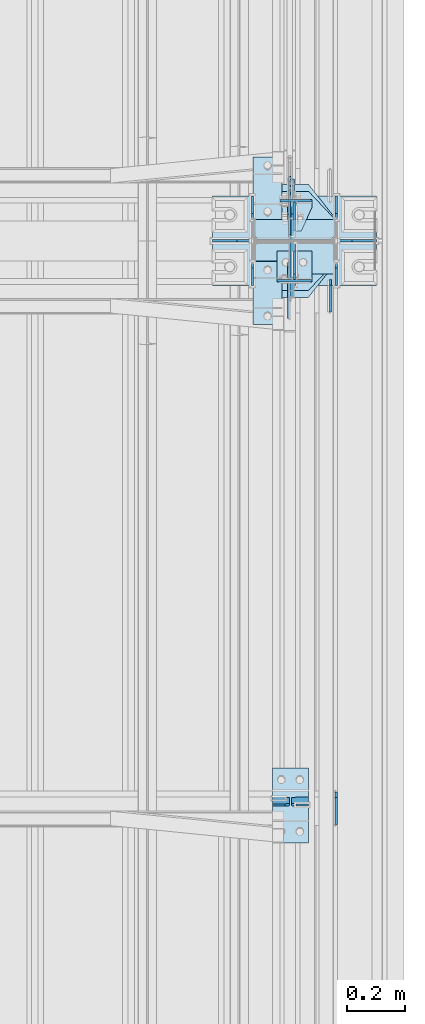
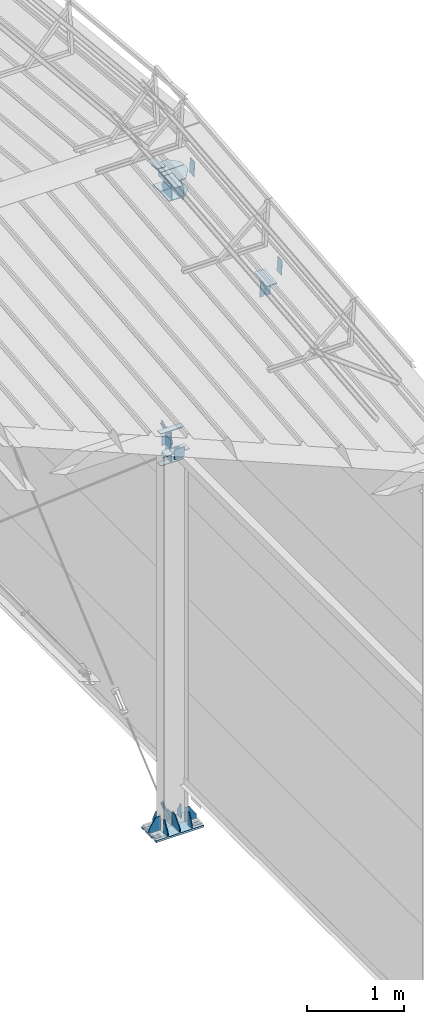
# One storey, part 157 of 709: 38 plates, 4 openings, 11 elements without a shape of their own.
"""IFC4 building model written with IfcOpenShell, lengths in millimetres."""

from ifc_helpers import new_model, si_unit, direction, frame, origin_with_axes, place, context, subcontext, project, spatial, line, arc, indexed_curve, outline, extrude, material, element, aggregate, save


model = new_model("IFC4")

# Units and contexts
model_context = context("Model", 3, precision=0.2, world=origin_with_axes(), true_north=direction((0.0, 1.0)))
body_context = subcontext(model_context, "Body", "Model", "MODEL_VIEW")
ifc_project = project(units=[si_unit("LENGTHUNIT", "METRE", prefix="MILLI"), si_unit("AREAUNIT", "SQUARE_METRE"), si_unit("VOLUMEUNIT", "CUBIC_METRE"), si_unit("MASSUNIT", "GRAM", prefix="KILO"), si_unit("TIMEUNIT", "SECOND"), si_unit("PLANEANGLEUNIT", "RADIAN"), si_unit("SOLIDANGLEUNIT", "STERADIAN"), si_unit("THERMODYNAMICTEMPERATUREUNIT", "DEGREE_CELSIUS"), si_unit("LUMINOUSINTENSITYUNIT", "LUMEN")], contexts=[model_context])

# Site, building, storey
site_placement = place(None, origin_with_axes())
site = spatial("IfcSite", under=ifc_project, at=site_placement, CompositionType="ELEMENT")
building_placement = place(site_placement, origin_with_axes())
building = spatial("IfcBuilding", under=site, at=building_placement, Name="Undefined", CompositionType="ELEMENT")
storey_placement = place(building_placement, origin_with_axes())
storey = spatial("IfcBuildingStorey", under=building, at=storey_placement, Name="Undefined", CompositionType="ELEMENT", Elevation=0.0)

# Assembly, plates
assembly_1_placement = place(storey_placement, frame((49837.5, 5500.0, 7445.307), z_axis=(1.0, 0.0, 0.0), x_axis=(0.0, 0.9950371902, 0.099503719)))
assembly_1 = element("IfcElementAssembly", 1, at=assembly_1_placement, inside=storey)
ifc_material = material(Name="C355-6", Category="STEEL")
plate_1_placement = place(assembly_1_placement, frame((3577.48939, 115.0, 62.0), z_axis=(-1.0, 0.0, 0.0), x_axis=(0.0, 0.0, -1.0)))
plate_1 = element("IfcPlate", 2, at=plate_1_placement, material=ifc_material, ObjectType="594", context=body_context, shape_type="SolidModel", body=[
    extrude(outline(indexed_curve([(0.0, 0.0), (43.5, 0.0), (58.5, 15.0), (58.5, 215.0), (43.5, 230.0), (0.0, 230.0)], segments=[line(1, 2, 3, 4, 5, 6, 1)])), frame((0.0, 0.0, 4.0), z_axis=(0.0, 0.0, 1.0), x_axis=(1.0, 0.0, 0.0)), (0.0, 0.0, -1.0), 8.0),
])
plate_2_placement = place(assembly_1_placement, frame((3577.48939, -115.0, -62.0), z_axis=(-1.0, 0.0, 0.0), x_axis=(0.0, 0.0, 1.0)))
plate_2 = element("IfcPlate", 3, at=plate_2_placement, material=ifc_material, ObjectType="594", context=body_context, shape_type="SolidModel", body=[
    extrude(outline(indexed_curve([(0.0, 0.0), (43.5, 0.0), (58.5, 15.0), (58.5, 215.0), (43.5, 230.0), (0.0, 230.0)], segments=[line(1, 2, 3, 4, 5, 6, 1)])), frame((0.0, 0.0, 4.0), z_axis=(0.0, 0.0, 1.0), x_axis=(1.0, 0.0, 0.0)), (0.0, 0.0, -1.0), 8.0),
])
plate_3_placement = place(assembly_1_placement, frame((5263.56002, 70.0, -6.5), z_axis=(0.0, 0.0, -1.0), x_axis=(1.0, 0.0, 0.0)))
plate_3 = element("IfcPlate", 4, at=plate_3_placement, material=ifc_material, ObjectType="472", context=body_context, shape_type="SolidModel", body=[
    extrude(outline(indexed_curve([(0.0, 0.0), (180.0, 0.0), (180.0, 160.0), (0.0, 160.0)], segments=[line(1, 2, 3, 4, 1)])), frame((0.0, 0.0, 4.0), z_axis=(0.0, 0.0, 1.0), x_axis=(1.0, 0.0, 0.0)), (0.0, 0.0, -1.0), 8.0),
])
aggregate(assembly_1, [plate_1, plate_2, plate_3])

# Assembly, plate
assembly_2_placement = place(storey_placement, frame((49837.5, 16500.0, 7445.307), z_axis=(-1.0, 0.0, 0.0), x_axis=(0.0, -0.9950371902, 0.099503719)))
assembly_2 = element("IfcElementAssembly", 5, at=assembly_2_placement, inside=storey)
plate_4_placement = place(assembly_2_placement, frame((5263.56002, 70.0, 6.5), z_axis=(0.0, 0.0, -1.0), x_axis=(1.0, 0.0, 0.0)))
plate_4 = element("IfcPlate", 6, at=plate_4_placement, material=ifc_material, ObjectType="472", context=body_context, shape_type="SolidModel", body=[
    extrude(outline(indexed_curve([(0.0, 0.0), (180.0, 0.0), (180.0, 160.0), (0.0, 160.0)], segments=[line(1, 2, 3, 4, 1)])), frame((0.0, 0.0, 4.0), z_axis=(0.0, 0.0, 1.0), x_axis=(1.0, 0.0, 0.0)), (0.0, 0.0, -1.0), 8.0),
])
aggregate(assembly_2, [plate_4])

# Assembly, plates
assembly_3_placement = place(storey_placement, frame((49851.0, 5500.0, 4610.0), z_axis=(0.0, 0.0, -1.0), x_axis=(0.0, 1.0, 0.0)))
assembly_3 = element("IfcElementAssembly", 7, at=assembly_3_placement, inside=storey)
plate_5_placement = place(assembly_3_placement, frame((5465.5, 0.0, -60.0), z_axis=(0.0, -1.0, 0.0), x_axis=(0.0, 0.0, 1.0)))
plate_5 = element("IfcPlate", 8, at=plate_5_placement, material=ifc_material, ObjectType="508", context=body_context, shape_type="SolidModel", body=[
    extrude(outline(indexed_curve([(0.0, 80.0), (36.0, 0.0), (56.0, 0.0), (56.0, 90.0), (46.0, 100.0), (0.0, 100.0)], segments=[line(1, 2, 3, 4, 5, 6, 1)])), frame((0.0, 0.0, 4.0), z_axis=(0.0, 0.0, 1.0), x_axis=(1.0, 0.0, 0.0)), (0.0, 0.0, -1.0), 8.0),
])
plate_6_placement = place(assembly_3_placement, frame((5465.5, -60.0, 0.0), z_axis=(0.0, 0.0, 1.0), x_axis=(0.0, 1.0, 0.0)))
plate_6 = element("IfcPlate", 9, at=plate_6_placement, material=ifc_material, ObjectType="507", context=body_context, shape_type="SolidModel", body=[
    extrude(outline(indexed_curve([(0.0, 0.0), (120.0, 0.0), (120.0, 100.0), (0.0, 100.0)], segments=[line(1, 2, 3, 4, 1)])), frame((0.0, 0.0, 4.0), z_axis=(0.0, 0.0, 1.0), x_axis=(1.0, 0.0, 0.0)), (0.0, 0.0, -1.0), 8.0),
])
plate_7_placement = place(assembly_3_placement, frame((5361.5, -60.0, 60.0), z_axis=(1.0, 0.0, 0.0), x_axis=(0.0, 0.0, -1.0)))
plate_7 = element("IfcPlate", 10, at=plate_7_placement, material=ifc_material, ObjectType="506", context=body_context, shape_type="SolidModel", body=[
    extrude(outline(indexed_curve([(0.0, 0.0), (120.0, 0.0), (120.0, 120.0), (0.0, 120.0)], segments=[line(1, 2, 3, 4, 1)])), frame((0.0, 0.0, 4.0), z_axis=(0.0, 0.0, 1.0), x_axis=(1.0, 0.0, 0.0)), (0.0, 0.0, -1.0), 8.0),
])
aggregate(assembly_3, [plate_5, plate_6, plate_7])

assembly_4_placement = place(storey_placement, frame((49851.0, 11000.0, 4610.0), z_axis=(0.0, 0.0, -1.0), x_axis=(0.0, 1.0, 0.0)))
assembly_4 = element("IfcElementAssembly", 11, at=assembly_4_placement, inside=storey)
plate_8_placement = place(assembly_4_placement, frame((138.5, -50.0, 60.0), z_axis=(-1.0, 0.0, 0.0), x_axis=(0.0, 1.0, 0.0)))
plate_8 = element("IfcPlate", 12, at=plate_8_placement, material=ifc_material, ObjectType="519", context=body_context, shape_type="SolidModel", body=[
    extrude(outline(indexed_curve([(0.0, 0.0), (110.0, 0.0), (110.0, 120.0), (0.0, 120.0)], segments=[line(1, 2, 3, 4, 1)])), frame((0.0, 0.0, 4.0), z_axis=(0.0, 0.0, 1.0), x_axis=(1.0, 0.0, 0.0)), (0.0, 0.0, -1.0), 8.0),
])
plate_9_placement = place(assembly_4_placement, frame((34.5, 0.0, 60.0), z_axis=(0.0, -1.0, 0.0), x_axis=(0.0, 0.0, -1.0)))
plate_9 = element("IfcPlate", 13, at=plate_9_placement, material=ifc_material, ObjectType="520", context=body_context, shape_type="SolidModel", body=[
    extrude(outline(indexed_curve([(0.0, 0.0), (120.0, 0.0), (120.0, 100.0), (0.0, 100.0)], segments=[line(1, 2, 3, 4, 1)])), frame((0.0, 0.0, 4.0), z_axis=(0.0, 0.0, 1.0), x_axis=(1.0, 0.0, 0.0)), (0.0, 0.0, -1.0), 8.0),
])
plate_10_placement = place(assembly_4_placement, frame((34.5, 60.0, 0.0), z_axis=(0.0, 0.0, 1.0), x_axis=(0.0, -1.0, 0.0)))
plate_10 = element("IfcPlate", 14, at=plate_10_placement, material=ifc_material, ObjectType="521", context=body_context, shape_type="SolidModel", body=[
    extrude(outline(indexed_curve([(0.0, 80.0), (36.0, 0.0), (56.0, 0.0), (56.0, 90.0), (46.0, 100.0), (0.0, 100.0)], segments=[line(1, 2, 3, 4, 5, 6, 1)])), frame((0.0, 0.0, 4.0), z_axis=(0.0, 0.0, 1.0), x_axis=(1.0, 0.0, 0.0)), (0.0, 0.0, -1.0), 8.0),
])
aggregate(assembly_4, [plate_8, plate_9, plate_10])

# Assembly, plate
assembly_5_placement = place(storey_placement, frame((49835.0, 11000.0, -155.0), z_axis=(1.0, 0.0, 0.0), x_axis=(0.0, 0.7603239329, 0.649544084)))
assembly_5 = element("IfcElementAssembly", 15, at=assembly_5_placement, inside=storey)
plate_11_placement = place(assembly_5_placement, frame((259.82193, 11.0, 0.0), z_axis=(0.0, 0.0, -1.0), x_axis=(-1.0, 0.0, 0.0)))
plate_11 = element("IfcPlate", 16, at=plate_11_placement, material=ifc_material, ObjectType="490", context=body_context, shape_type="SolidModel", body=[
    extrude(outline(indexed_curve([(0.0, 0.0), (80.0, 0.0), (80.0, -22.0), (0.0, -22.0), (0.0, -46.0), (200.0, -46.0), (200.0, 24.0), (0.0, 24.0)], segments=[line(1, 2, 3, 4, 5, 6, 7, 8, 1)])), frame((0.0, 0.0, 4.0), z_axis=(0.0, 0.0, 1.0), x_axis=(1.0, 0.0, 0.0)), (0.0, 0.0, -1.0), 8.0),
])
aggregate(assembly_5, [plate_11])

assembly_6_placement = place(storey_placement, frame((49835.0, 11074.5, 4480.0), z_axis=(1.0, 0.0, 0.0), x_axis=(0.0, 0.7603239329, -0.649544084)))
assembly_6 = element("IfcElementAssembly", 17, at=assembly_6_placement, inside=storey)
plate_12_placement = place(assembly_6_placement, frame((150.0, -35.0, 0.0), z_axis=(0.0, 0.0, -1.0), x_axis=(-1.0, 0.0, 0.0)))
plate_12 = element("IfcPlate", 18, at=plate_12_placement, material=ifc_material, ObjectType="525", context=body_context, shape_type="SolidModel", body=[
    extrude(outline(indexed_curve([(0.0, 0.0), (200.0, 0.0), (200.0, 70.0), (0.0, 70.0), (0.0, 46.0), (80.0, 46.0), (80.0, 24.0), (0.0, 24.0)], segments=[line(1, 2, 3, 4, 5, 6, 7, 8, 1)])), frame((0.0, 0.0, 4.0), z_axis=(0.0, 0.0, 1.0), x_axis=(1.0, 0.0, 0.0)), (0.0, 0.0, -1.0), 8.0),
])
aggregate(assembly_6, [plate_12])

assembly_7_placement = place(storey_placement, frame((49835.0, 11074.5, 4740.0), z_axis=(1.0, 0.0, 0.0), x_axis=(0.0, 0.9030466941, 0.429542394)))
assembly_7 = element("IfcElementAssembly", 19, at=assembly_7_placement, inside=storey)
plate_13_placement = place(assembly_7_placement, frame((150.0, -35.0, 0.0), z_axis=(0.0, 0.0, -1.0), x_axis=(-1.0, 0.0, 0.0)))
plate_13 = element("IfcPlate", 20, at=plate_13_placement, material=ifc_material, ObjectType="525", context=body_context, shape_type="SolidModel", body=[
    extrude(outline(indexed_curve([(0.0, 0.0), (200.0, 0.0), (200.0, 70.0), (0.0, 70.0), (0.0, 46.0), (80.0, 46.0), (80.0, 24.0), (0.0, 24.0)], segments=[line(1, 2, 3, 4, 5, 6, 7, 8, 1)])), frame((0.0, 0.0, 4.0), z_axis=(0.0, 0.0, 1.0), x_axis=(1.0, 0.0, 0.0)), (0.0, 0.0, -1.0), 8.0),
])
aggregate(assembly_7, [plate_13])

# Assembly, plates, voiding features
assembly_8_placement = place(storey_placement, frame((49851.0, 11000.0, -200.0), z_axis=(0.0, -1.0, 0.0), x_axis=(0.0, 0.0, 1.0)))
assembly_8 = element("IfcElementAssembly", 21, at=assembly_8_placement, inside=storey)
plate_14_placement = place(assembly_8_placement, frame((8313.83583, 143.0, -0.59702), z_axis=(0.9950371902, 0.0, -0.099503719), x_axis=(0.0, -1.0, 0.0)))
plate_14 = element("IfcPlate", 22, at=plate_14_placement, material=ifc_material, ObjectType="471", context=body_context, shape_type="SolidModel", body=[
    extrude(outline(indexed_curve([(0.0, 0.0), (286.0, 0.0), (286.0, 74.87157), (191.5, 195.07157), (0.0, 195.07157)], segments=[line(1, 2, 3, 4, 5, 1)])), frame((0.0, 0.0, 6.0), z_axis=(0.0, 0.0, 1.0), x_axis=(1.0, 0.0, 0.0)), (0.0, 0.0, -1.0), 12.0),
])
plate_15_placement = place(assembly_8_placement, frame((8072.48821, 140.0, -2.15298), z_axis=(0.9950371902, 0.0, -0.099503719), x_axis=(0.0, -1.0, 0.0)))
plate_15 = element("IfcPlate", 23, at=plate_15_placement, material=ifc_material, ObjectType="470", context=body_context, shape_type="SolidModel", body=[
    extrude(outline(indexed_curve([(0.0, 0.0), (280.0, 0.0), (280.0, 72.10786), (188.5, 169.50835), (0.0, 169.50835)], segments=[line(1, 2, 3, 4, 5, 1)])), frame((0.0, 0.0, 6.0), z_axis=(0.0, 0.0, 1.0), x_axis=(1.0, 0.0, 0.0)), (0.0, 0.0, -1.0), 12.0),
])
plate_16_placement = place(assembly_8_placement, frame((8062.58182, 10.0, -171.51613), z_axis=(0.0, -1.0, 0.0), x_axis=(0.9950371902, 0.0, -0.099503719)))
plate_16 = element("IfcPlate", 24, at=plate_16_placement, material=ifc_material, ObjectType="469", context=body_context, shape_type="SolidModel", body=[
    extrude(outline(indexed_curve([(0.0, 0.0), (226.0, 0.0), (226.0, 192.20786), (0.0, 169.60786)], segments=[line(1, 2, 3, 4, 1)])), frame((0.0, 0.0, 6.0), z_axis=(0.0, 0.0, 1.0), x_axis=(1.0, 0.0, 0.0)), (0.0, 0.0, -1.0), 12.0),
])
plate_17_placement = place(assembly_8_placement, frame((8072.48821, -140.0, 2.15298), z_axis=(0.9950371902, 0.0, 0.099503719), x_axis=(0.0, 1.0, 0.0)))
plate_17 = element("IfcPlate", 25, at=plate_17_placement, material=ifc_material, ObjectType="470", context=body_context, shape_type="SolidModel", body=[
    extrude(outline(indexed_curve([(0.0, 0.0), (280.0, 0.0), (280.0, 169.50835), (91.5, 169.50835), (0.0, 72.10786)], segments=[line(1, 2, 3, 4, 5, 1)])), frame((0.0, 0.0, 6.0), z_axis=(0.0, 0.0, 1.0), x_axis=(1.0, 0.0, 0.0)), (0.0, 0.0, -1.0), 12.0),
])
plate_18_placement = place(assembly_8_placement, frame((8313.83583, -143.0, 0.59702), z_axis=(0.9950371902, 0.0, 0.099503719), x_axis=(0.0, 1.0, 0.0)))
plate_18 = element("IfcPlate", 26, at=plate_18_placement, material=ifc_material, ObjectType="479", context=body_context, shape_type="SolidModel", body=[
    extrude(outline(indexed_curve([(0.0, 0.0), (286.0, 0.0), (286.0, 195.07157), (94.5, 195.07157), (0.0, 74.87157)], segments=[line(1, 2, 3, 4, 5, 1)])), frame((0.0, 0.0, 6.0), z_axis=(0.0, 0.0, 1.0), x_axis=(1.0, 0.0, 0.0)), (0.0, 0.0, -1.0), 12.0),
])
plate_19_placement = place(assembly_8_placement, frame((8062.58182, 10.0, 171.51613), z_axis=(0.0, 1.0, 0.0), x_axis=(0.9950371902, 0.0, 0.099503719)))
plate_19 = element("IfcPlate", 27, at=plate_19_placement, material=ifc_material, ObjectType="469", context=body_context, shape_type="SolidModel", body=[
    extrude(outline(indexed_curve([(0.0, 0.0), (226.0, 0.0), (226.0, 192.20786), (0.0, 169.60786)], segments=[line(1, 2, 3, 4, 1)])), frame((0.0, 0.0, 6.0), z_axis=(0.0, 0.0, 1.0), x_axis=(1.0, 0.0, 0.0)), (0.0, 0.0, -1.0), 12.0),
])
plate_20_placement = place(assembly_8_placement, frame((25.0, -145.0, 74.5), z_axis=(0.0, 1.0, 0.0), x_axis=(0.0, 0.0, 1.0)))
plate_20 = element("IfcPlate", 28, at=plate_20_placement, material=ifc_material, ObjectType="426", context=body_context, shape_type="SolidModel", body=[
    extrude(outline(indexed_curve([(0.0, 0.0), (80.5, 0.0), (80.5, 50.0), (20.0, 175.0), (0.0, 175.0)], segments=[line(1, 2, 3, 4, 5, 1)])), frame((0.0, 0.0, 4.0), z_axis=(0.0, 0.0, 1.0), x_axis=(1.0, 0.0, 0.0)), (0.0, 0.0, -1.0), 8.0),
])
plate_21_placement = place(assembly_8_placement, frame((25.0, 149.0, 0.0), z_axis=(0.0, 0.0, -1.0), x_axis=(0.0, 1.0, 0.0)))
plate_21 = element("IfcPlate", 29, at=plate_21_placement, material=ifc_material, ObjectType="418", context=body_context, shape_type="SolidModel", body=[
    extrude(outline(indexed_curve([(0.0, 0.0), (135.0, 0.0), (135.0, 50.0), (50.0, 175.0), (0.0, 175.0)], segments=[line(1, 2, 3, 4, 5, 1)])), frame((0.0, 0.0, 4.0), z_axis=(0.0, 0.0, 1.0), x_axis=(1.0, 0.0, 0.0)), (0.0, 0.0, -1.0), 8.0),
])
plate_22_placement = place(assembly_8_placement, frame((25.0, 0.0, 2.75), z_axis=(0.0, 1.0, 0.0), x_axis=(0.0, 0.0, 1.0)))
plate_22 = element("IfcPlate", 30, at=plate_22_placement, material=ifc_material, ObjectType="417", context=body_context, shape_type="SolidModel", body=[
    extrude(outline(indexed_curve([(0.0, 0.0), (152.25, 0.0), (152.25, 50.0), (50.0, 175.0), (0.0, 175.0)], segments=[line(1, 2, 3, 4, 5, 1)])), frame((0.0, 0.0, 4.0), z_axis=(0.0, 0.0, 1.0), x_axis=(1.0, 0.0, 0.0)), (0.0, 0.0, -1.0), 8.0),
])
plate_23_placement = place(assembly_8_placement, frame((25.0, 145.0, 74.5), z_axis=(0.0, 1.0, 0.0), x_axis=(0.0, 0.0, 1.0)))
plate_23 = element("IfcPlate", 31, at=plate_23_placement, material=ifc_material, ObjectType="426", context=body_context, shape_type="SolidModel", body=[
    extrude(outline(indexed_curve([(0.0, 0.0), (80.5, 0.0), (80.5, 50.0), (20.0, 175.0), (0.0, 175.0)], segments=[line(1, 2, 3, 4, 5, 1)])), frame((0.0, 0.0, 4.0), z_axis=(0.0, 0.0, 1.0), x_axis=(1.0, 0.0, 0.0)), (0.0, 0.0, -1.0), 8.0),
])
plate_24_placement = place(assembly_8_placement, frame((25.0, -145.0, -74.5), z_axis=(0.0, -1.0, 0.0), x_axis=(0.0, 0.0, -1.0)))
plate_24 = element("IfcPlate", 32, at=plate_24_placement, material=ifc_material, ObjectType="426", context=body_context, shape_type="SolidModel", body=[
    extrude(outline(indexed_curve([(0.0, 0.0), (80.5, 0.0), (80.5, 50.0), (20.0, 175.0), (0.0, 175.0)], segments=[line(1, 2, 3, 4, 5, 1)])), frame((0.0, 0.0, 4.0), z_axis=(0.0, 0.0, 1.0), x_axis=(1.0, 0.0, 0.0)), (0.0, 0.0, -1.0), 8.0),
])
plate_25_placement = place(assembly_8_placement, frame((25.0, 145.0, -74.5), z_axis=(0.0, -1.0, 0.0), x_axis=(0.0, 0.0, -1.0)))
plate_25 = element("IfcPlate", 33, at=plate_25_placement, material=ifc_material, ObjectType="426", context=body_context, shape_type="SolidModel", body=[
    extrude(outline(indexed_curve([(0.0, 0.0), (80.5, 0.0), (80.5, 50.0), (20.0, 175.0), (0.0, 175.0)], segments=[line(1, 2, 3, 4, 5, 1)])), frame((0.0, 0.0, 4.0), z_axis=(0.0, 0.0, 1.0), x_axis=(1.0, 0.0, 0.0)), (0.0, 0.0, -1.0), 8.0),
])
plate_26_placement = place(assembly_8_placement, frame((12.5, -284.0, 155.0), z_axis=(1.0, 0.0, 0.0), x_axis=(0.0, 0.0, -1.0)))
plate_26 = element("IfcPlate", 34, at=plate_26_placement, material=ifc_material, context=body_context, shape_type="SolidModel", body=[
    extrude(outline(indexed_curve([(0.0, 0.0), (310.0, 0.0), (310.0, 568.0), (0.0, 568.0)], segments=[line(1, 2, 3, 4, 1)])), frame((0.0, 0.0, 12.5), z_axis=(0.0, 0.0, 1.0), x_axis=(1.0, 0.0, 0.0)), (0.0, 0.0, -1.0), 25.0),
])
voiding_feature_1_placement = place(plate_26_placement, frame((40.0, 568.0, 0.0), z_axis=(0.0, 0.0, -1.0), x_axis=(1.0, 0.0, 0.0)))
element("IfcVoidingFeature", 35, at=voiding_feature_1_placement, cuts=plate_26, PredefinedType="HOLE", context=body_context, shape_type="SolidModel", body=[
    extrude(outline(indexed_curve([(0.0, 0.0), (50.0, 0.0), (50.0, 60.0), (42.67767, 77.67767), (25.0, 85.0), (25.0, 85.0), (7.32233, 77.67767), (0.0, 60.0)], segments=[line(1, 2, 3), arc(3, 4, 5), line(5, 6), arc(6, 7, 8), line(8, 1)])), frame((0.0, 0.0, 12.5), z_axis=(0.0, 0.0, 1.0), x_axis=(1.0, 0.0, 0.0)), (0.0, 0.0, -1.0), 25.0),
])
voiding_feature_2_placement = place(plate_26_placement, frame((40.0, 0.0, 0.0), z_axis=(0.0, 0.0, 1.0), x_axis=(1.0, 0.0, 0.0)))
element("IfcVoidingFeature", 36, at=voiding_feature_2_placement, cuts=plate_26, PredefinedType="HOLE", context=body_context, shape_type="SolidModel", body=[
    extrude(outline(indexed_curve([(0.0, 0.0), (50.0, 0.0), (50.0, 60.0), (42.67767, 77.67767), (25.0, 85.0), (25.0, 85.0), (7.32233, 77.67767), (0.0, 60.0)], segments=[line(1, 2, 3), arc(3, 4, 5), line(5, 6), arc(6, 7, 8), line(8, 1)])), frame((0.0, 0.0, 12.5), z_axis=(0.0, 0.0, 1.0), x_axis=(1.0, 0.0, 0.0)), (0.0, 0.0, -1.0), 25.0),
])
voiding_feature_3_placement = place(plate_26_placement, frame((270.0, 568.0, 0.0), z_axis=(0.0, 0.0, 1.0), x_axis=(-1.0, 0.0, 0.0)))
element("IfcVoidingFeature", 37, at=voiding_feature_3_placement, cuts=plate_26, PredefinedType="HOLE", context=body_context, shape_type="SolidModel", body=[
    extrude(outline(indexed_curve([(0.0, 0.0), (50.0, 0.0), (50.0, 60.0), (42.67767, 77.67767), (25.0, 85.0), (25.0, 85.0), (7.32233, 77.67767), (0.0, 60.0)], segments=[line(1, 2, 3), arc(3, 4, 5), line(5, 6), arc(6, 7, 8), line(8, 1)])), frame((0.0, 0.0, 12.5), z_axis=(0.0, 0.0, 1.0), x_axis=(1.0, 0.0, 0.0)), (0.0, 0.0, -1.0), 25.0),
])
voiding_feature_4_placement = place(plate_26_placement, frame((270.0, 0.0, 0.0), z_axis=(0.0, 0.0, -1.0), x_axis=(-1.0, 0.0, 0.0)))
element("IfcVoidingFeature", 38, at=voiding_feature_4_placement, cuts=plate_26, PredefinedType="HOLE", context=body_context, shape_type="SolidModel", body=[
    extrude(outline(indexed_curve([(0.0, 0.0), (50.0, 0.0), (50.0, 60.0), (42.67767, 77.67767), (25.0, 85.0), (25.0, 85.0), (7.32233, 77.67767), (0.0, 60.0)], segments=[line(1, 2, 3), arc(3, 4, 5), line(5, 6), arc(6, 7, 8), line(8, 1)])), frame((0.0, 0.0, 12.5), z_axis=(0.0, 0.0, 1.0), x_axis=(1.0, 0.0, 0.0)), (0.0, 0.0, -1.0), 25.0),
])
plate_27_placement = place(assembly_8_placement, frame((25.0, -149.0, 0.0), z_axis=(0.0, 0.0, 1.0), x_axis=(0.0, -1.0, 0.0)))
plate_27 = element("IfcPlate", 39, at=plate_27_placement, material=ifc_material, ObjectType="418", context=body_context, shape_type="SolidModel", body=[
    extrude(outline(indexed_curve([(0.0, 0.0), (135.0, 0.0), (135.0, 50.0), (50.0, 175.0), (0.0, 175.0)], segments=[line(1, 2, 3, 4, 5, 1)])), frame((0.0, 0.0, 4.0), z_axis=(0.0, 0.0, 1.0), x_axis=(1.0, 0.0, 0.0)), (0.0, 0.0, -1.0), 8.0),
])
plate_28_placement = place(assembly_8_placement, frame((4802.0, 140.0, 114.5), z_axis=(-1.0, 0.0, 0.0), x_axis=(0.0, 0.0, -1.0)))
plate_28 = element("IfcPlate", 40, at=plate_28_placement, material=ifc_material, ObjectType="529", context=body_context, shape_type="SolidModel", body=[
    extrude(outline(indexed_curve([(0.0, 0.0), (95.75, 0.0), (110.75, 15.0), (110.75, 265.0), (95.75, 280.0), (0.0, 280.0)], segments=[line(1, 2, 3, 4, 5, 6, 1)])), frame((0.0, 0.0, 4.0), z_axis=(0.0, 0.0, 1.0), x_axis=(1.0, 0.0, 0.0)), (0.0, 0.0, -1.0), 8.0),
])
plate_29_placement = place(assembly_8_placement, frame((114.59681, 6.0, -150.74592), z_axis=(0.0, -1.0, 0.0), x_axis=(0.7603239329, 0.0, 0.649544084)))
plate_29 = element("IfcPlate", 41, at=plate_29_placement, material=ifc_material, ObjectType="518", context=body_context, shape_type="SolidModel", body=[
    extrude(outline(indexed_curve([(0.0, 0.0), (90.0, 0.0), (148.1582, 68.07709), (39.41213, 160.97876), (18.26411, 159.31706), (-68.1226, 58.19708)], segments=[line(1, 2, 3, 4, 5, 6, 1)])), frame((0.0, 0.0, 6.0), z_axis=(0.0, 0.0, 1.0), x_axis=(1.0, 0.0, 0.0)), (0.0, 0.0, -1.0), 12.0),
])
plate_30_placement = place(assembly_8_placement, frame((5002.11422, 10.0, -100.32293), z_axis=(0.0, 1.0, 0.0), x_axis=(-0.9030466941, 0.0, -0.429542394)))
plate_30 = element("IfcPlate", 42, at=plate_30_placement, material=ifc_material, ObjectType="526", context=body_context, shape_type="SolidModel", body=[
    extrude(outline(indexed_curve([(0.0, 0.0), (90.0, 0.0), (116.3645, 39.65068), (242.79103, 99.78661), (307.10808, 100.20876), (343.7922, 182.39316), (315.6414, 241.57587), (295.65257, 248.67843), (-28.36601, 94.55605), (-35.46857, 74.56721)], segments=[line(1, 2, 3, 4, 5, 6, 7, 8, 9, 10, 1)])), frame((0.0, 0.0, 6.0), z_axis=(0.0, 0.0, 1.0), x_axis=(1.0, 0.0, 0.0)), (0.0, 0.0, -1.0), 12.0),
])
plate_31_placement = place(assembly_8_placement, frame((5008.11422, -140.0, -74.5), z_axis=(-1.0, 0.0, 0.0), x_axis=(0.0, 0.0, 1.0)))
plate_31 = element("IfcPlate", 43, at=plate_31_placement, material=ifc_material, ObjectType="523", context=body_context, shape_type="SolidModel", body=[
    extrude(outline(indexed_curve([(0.0, 0.0), (55.75, 0.0), (70.75, 15.0), (70.75, 265.0), (55.75, 280.0), (0.0, 280.0)], segments=[line(1, 2, 3, 4, 5, 6, 1)])), frame((0.0, 0.0, 6.0), z_axis=(0.0, 0.0, 1.0), x_axis=(1.0, 0.0, 0.0)), (0.0, 0.0, -1.0), 12.0),
])
plate_32_placement = place(assembly_8_placement, frame((4607.30822, -140.0, -74.5), z_axis=(-1.0, 0.0, 0.0), x_axis=(0.0, 0.0, 1.0)))
plate_32 = element("IfcPlate", 44, at=plate_32_placement, material=ifc_material, ObjectType="524", context=body_context, shape_type="SolidModel", body=[
    extrude(outline(indexed_curve([(0.0, 0.0), (55.75, 0.0), (70.75, 15.0), (70.75, 265.0), (55.75, 280.0), (0.0, 280.0)], segments=[line(1, 2, 3, 4, 5, 6, 1)])), frame((0.0, 0.0, 4.0), z_axis=(0.0, 0.0, 1.0), x_axis=(1.0, 0.0, 0.0)), (0.0, 0.0, -1.0), 8.0),
])
plate_33_placement = place(assembly_8_placement, frame((7999.66592, 6.0, -213.1198), z_axis=(0.0, 1.0, 0.0), x_axis=(-0.866144648, 0.0, 0.499793406)))
plate_33 = element("IfcPlate", 45, at=plate_33_placement, material=ifc_material, ObjectType="528", context=body_context, shape_type="SolidModel", body=[
    extrude(outline(indexed_curve([(0.0, 0.0), (90.0, 0.0), (172.66002, 143.25027), (60.33346, 208.06631), (41.17437, 201.88955), (-21.85505, 62.13712)], segments=[line(1, 2, 3, 4, 5, 6, 1)])), frame((0.0, 0.0, 6.0), z_axis=(0.0, 0.0, 1.0), x_axis=(1.0, 0.0, 0.0)), (0.0, 0.0, -1.0), 12.0),
])
aggregate(assembly_8, [plate_14, plate_15, plate_16, plate_17, plate_18, plate_19, plate_20, plate_21, plate_22, plate_23, plate_24, plate_25, plate_26, plate_27, plate_28, plate_29, plate_30, plate_31, plate_32, plate_33])

# Assembly, plates
assembly_9_placement = place(storey_placement, frame((46000.0, 9036.65012, 8032.12913), z_axis=(0.0, 0.9950371902, 0.099503719), x_axis=(1.0, 0.0, 0.0)))
assembly_9 = element("IfcElementAssembly", 46, at=assembly_9_placement, inside=storey)
plate_34_placement = place(assembly_9_placement, frame((3775.5, 104.0, -130.0), z_axis=(0.0, 1.0, 0.0), x_axis=(0.0, 0.0, 1.0)))
plate_34 = element("IfcPlate", 47, at=plate_34_placement, material=ifc_material, ObjectType="593", context=body_context, shape_type="SolidModel", body=[
    extrude(outline(indexed_curve([(0.0, 0.0), (260.0, 0.0), (260.0, 124.0), (0.0, 124.0)], segments=[line(1, 2, 3, 4, 1)])), frame((0.0, 0.0, 4.0), z_axis=(0.0, 0.0, 1.0), x_axis=(1.0, 0.0, 0.0)), (0.0, 0.0, -1.0), 8.0),
])
plate_35_placement = place(assembly_9_placement, frame((3996.0, -97.0, 47.0), z_axis=(1.0, 0.0, 0.0), x_axis=(0.0, 0.0, -1.0)))
plate_35 = element("IfcPlate", 48, at=plate_35_placement, material=ifc_material, ObjectType="592", context=body_context, shape_type="SolidModel", body=[
    extrude(outline(indexed_curve([(0.0, 0.0), (94.0, 0.0), (94.0, 194.0), (0.0, 194.0)], segments=[line(1, 2, 3, 4, 1)])), frame((0.0, 0.0, 4.0), z_axis=(0.0, 0.0, 1.0), x_axis=(1.0, 0.0, 0.0)), (0.0, 0.0, -1.0), 8.0),
])
aggregate(assembly_9, [plate_34, plate_35])

assembly_10_placement = place(storey_placement, frame((46000.0, 10809.95037, 8209.45915), z_axis=(0.0, 0.9950371902, 0.099503719), x_axis=(1.0, 0.0, 0.0)))
assembly_10 = element("IfcElementAssembly", 49, at=assembly_10_placement, inside=storey)
plate_36_placement = place(assembly_10_placement, frame((3976.0, -97.0, 47.0), z_axis=(1.0, 0.0, 0.0), x_axis=(0.0, 0.0, -1.0)))
plate_36 = element("IfcPlate", 50, at=plate_36_placement, material=ifc_material, ObjectType="592", context=body_context, shape_type="SolidModel", body=[
    extrude(outline(indexed_curve([(0.0, 0.0), (94.0, 0.0), (94.0, 194.0), (0.0, 194.0)], segments=[line(1, 2, 3, 4, 1)])), frame((0.0, 0.0, 4.0), z_axis=(0.0, 0.0, 1.0), x_axis=(1.0, 0.0, 0.0)), (0.0, 0.0, -1.0), 8.0),
])
plate_37_placement = place(assembly_10_placement, frame((3808.0, 104.0, 110.0), z_axis=(0.0, -1.0, 0.0), x_axis=(-1.0, 0.0, 0.0)))
plate_37 = element("IfcPlate", 51, at=plate_37_placement, material=ifc_material, ObjectType="591", context=body_context, shape_type="SolidModel", body=[
    extrude(outline(indexed_curve([(0.0, 0.0), (100.0, 0.0), (100.0, 220.0), (0.0, 220.0)], segments=[line(1, 2, 3, 4, 1)])), frame((0.0, 0.0, 4.0), z_axis=(0.0, 0.0, 1.0), x_axis=(1.0, 0.0, 0.0)), (0.0, 0.0, -1.0), 8.0),
])
aggregate(assembly_10, [plate_36, plate_37])

# Assembly, plate
assembly_11_placement = place(storey_placement, frame((50000.0, 11190.04963, 8209.45915), z_axis=(0.0, -0.9950371902, 0.099503719), x_axis=(-1.0, 0.0, 0.0)))
assembly_11 = element("IfcElementAssembly", 52, at=assembly_11_placement, inside=storey)
plate_38_placement = place(assembly_11_placement, frame((292.0, 104.0, 110.0), z_axis=(0.0, -1.0, 0.0), x_axis=(-1.0, 0.0, 0.0)))
plate_38 = element("IfcPlate", 53, at=plate_38_placement, material=ifc_material, ObjectType="591", context=body_context, shape_type="SolidModel", body=[
    extrude(outline(indexed_curve([(0.0, 0.0), (100.0, 0.0), (100.0, 220.0), (0.0, 220.0)], segments=[line(1, 2, 3, 4, 1)])), frame((0.0, 0.0, 4.0), z_axis=(0.0, 0.0, 1.0), x_axis=(1.0, 0.0, 0.0)), (0.0, 0.0, -1.0), 8.0),
])
aggregate(assembly_11, [plate_38])

save(model, "model.ifc")
